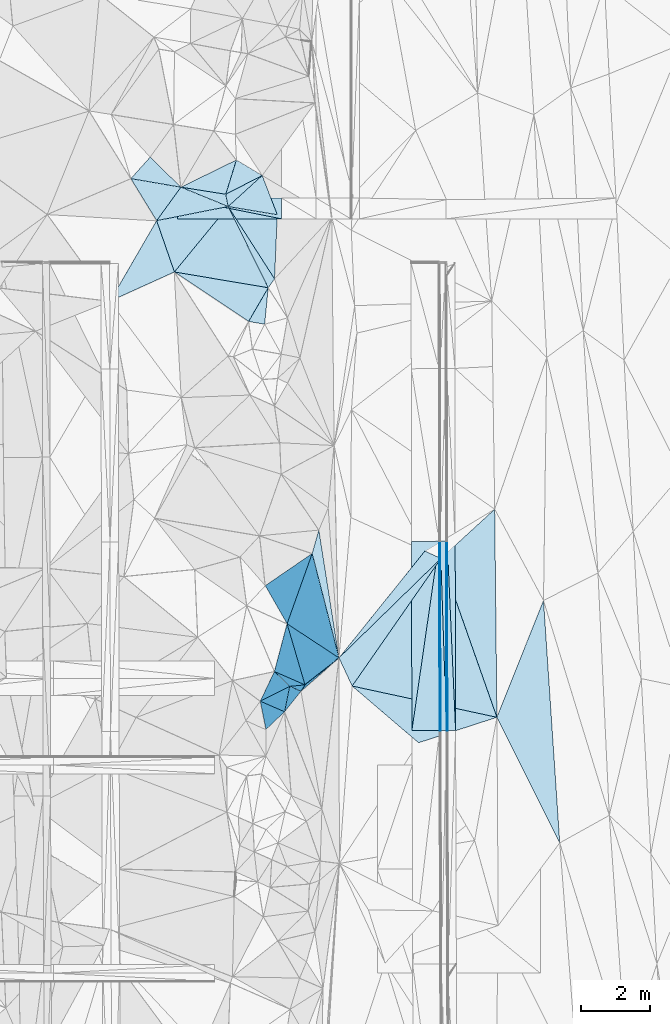
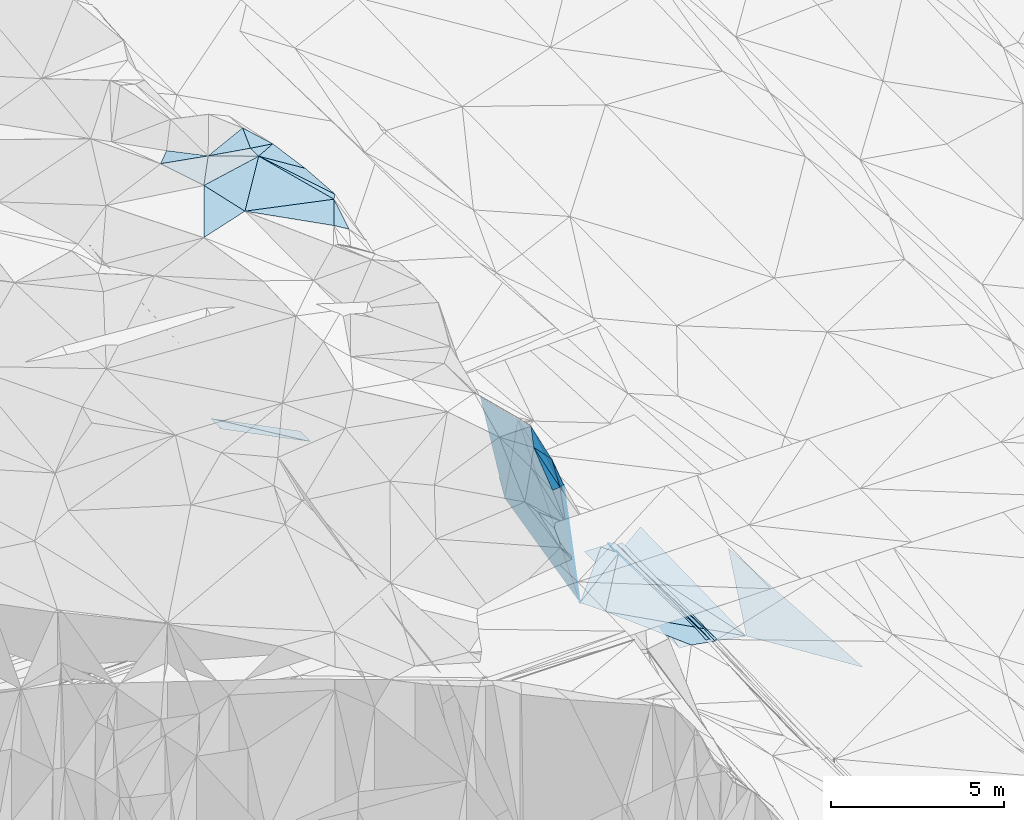
# One storey, part 81 of 275: 45 plates.
"""IFC2X3 building model written with IfcOpenShell, lengths in millimetres."""

from ifc_helpers import new_model, si_unit, frame, origin_with_axes, place, context, subcontext, project, spatial, polyline, outline, extrude, material, type_object, element, save


model = new_model("IFC2X3")

# Units and contexts
model_context = context("Model", 3, precision=1e-05, world=origin_with_axes())
body_context = subcontext(model_context, "Body", "Model", "MODEL_VIEW")
ifc_project = project(units=[si_unit("LENGTHUNIT", "METRE", prefix="MILLI"), si_unit("AREAUNIT", "SQUARE_METRE"), si_unit("VOLUMEUNIT", "CUBIC_METRE"), si_unit("MASSUNIT", "GRAM", prefix="KILO"), si_unit("TIMEUNIT", "SECOND"), si_unit("PLANEANGLEUNIT", "RADIAN"), si_unit("SOLIDANGLEUNIT", "STERADIAN"), si_unit("THERMODYNAMICTEMPERATUREUNIT", "DEGREE_CELSIUS"), si_unit("LUMINOUSINTENSITYUNIT", "LUMEN")], contexts=[model_context])

# Site, building, storey
site_placement = place(None, origin_with_axes())
site = spatial("IfcSite", under=ifc_project, at=site_placement, CompositionType="ELEMENT")
building_placement = place(site_placement, origin_with_axes())
building = spatial("IfcBuilding", under=site, at=building_placement, Name="Undefined", CompositionType="ELEMENT")
storey_placement = place(building_placement, origin_with_axes())
storey = spatial("IfcBuildingStorey", under=building, at=storey_placement, Name="Undefined", CompositionType="ELEMENT", Elevation=0.0)

# Plates
ifc_material = material()
plate_type_1 = type_object("IfcPlateType", PredefinedType="NOTDEFINED")
plate_1_placement = place(storey_placement, frame((-94105.8883228957, 67288.7747028968, 42290.6607411696), z_axis=(-0.970143260568586, 0.00267145694743371, -0.242517870044931), x_axis=(-0.00764659711849112, 0.999105321574431, 0.0415943019434257)))
element("IfcPlate", 1, at=plate_1_placement, inside=storey, type_object=plate_type_1, material=ifc_material, Name="00_PR", context=body_context, shape_type="SweptSolid", body=[
    extrude(outline(polyline([(0.0, 0.0), (5462.623046875, -2.93221091851592e-08), (5457.62060546875, 123.591766357422), (0.0, 0.0)])), frame((-8.85201319254618e-08, 2.18876761149539e-07, -0.5000001331573), z_axis=(0.0, 0.0, 1.0), x_axis=(1.0, 0.0, 0.0)), (0.0, 0.0, 1.0), 1.0),
])
plate_2_placement = place(storey_placement, frame((-94135.8859445538, 67288.478023209, 42410.6607449865), z_axis=(-0.970145116736712, 0.00267113368634195, -0.242510448263043), x_axis=(-0.00215655711744766, 0.999804800462276, 0.0196395069690803)))
element("IfcPlate", 2, at=plate_2_placement, inside=storey, type_object=plate_type_1, material=ifc_material, Name="00_PR", context=body_context, shape_type="SweptSolid", body=[
    extrude(outline(polyline([(0.0, 0.0), (5459.09814453125, -3.5026459954679e-08), (-2.12481045722961, 123.674697875977), (0.0, 0.0)])), frame((-8.85201319254618e-08, 2.18876761149539e-07, -0.5000001331573), z_axis=(0.0, 0.0, 1.0), x_axis=(1.0, 0.0, 0.0)), (0.0, 0.0, 1.0), 1.0),
])
plate_type_2 = type_object("IfcPlateType", PredefinedType="NOTDEFINED")
plate_3_placement = place(storey_placement, frame((-94317.184155341, 72746.2287388931, 42517.496195845), z_axis=(-0.0200433417983263, 0.0195917396136776, -0.999607136923534), x_axis=(0.00215672009275164, -0.999804810953611, -0.0196389549736261)))
element("IfcPlate", 3, at=plate_3_placement, inside=storey, type_object=plate_type_2, material=ifc_material, Name="00_PR", context=body_context, shape_type="SweptSolid", body=[
    extrude(outline(polyline([(0.0, 0.0), (5459.251953125, 9.13860276341438e-09), (5459.25341796875, 30.0063400268555), (0.0, 0.0)])), frame((-8.85201319254618e-08, 2.18876761149539e-07, -0.5000001331573), z_axis=(0.0, 0.0, 1.0), x_axis=(1.0, 0.0, 0.0)), (0.0, 0.0, 1.0), 1.0),
])
plate_4_placement = place(storey_placement, frame((-94317.184155341, 72746.2287388931, 42517.496195845), z_axis=(-0.0200254527998118, 0.0195917848498762, -0.999607494573024), x_axis=(-0.00333853088786553, -0.999803721825275, -0.0195287489573384)))
element("IfcPlate", 4, at=plate_4_placement, inside=storey, type_object=plate_type_2, material=ifc_material, Name="00_PR", context=body_context, shape_type="SweptSolid", body=[
    extrude(outline(polyline([(0.0, 0.0), (5459.3359375, 3.60741978511214e-08), (0.138779759407043, 30.0050926208496), (0.0, 0.0)])), frame((-8.85201319254618e-08, 2.18876761149539e-07, -0.5000001331573), z_axis=(0.0, 0.0, 1.0), x_axis=(1.0, 0.0, 0.0)), (0.0, 0.0, 1.0), 1.0),
])
plate_type_3 = type_object("IfcPlateType", PredefinedType="NOTDEFINED")
plate_5_placement = place(storey_placement, frame((-100194.895762429, 83737.6100265071, 52559.5807201989), z_axis=(-0.517947939485658, 0.169130371912813, -0.838525401689892), x_axis=(0.724175433162463, -0.435056636844825, -0.535066037738547)))
element("IfcPlate", 5, at=plate_5_placement, inside=storey, type_object=plate_type_3, material=ifc_material, Name="00", context=body_context, shape_type="SweptSolid", body=[
    extrude(outline(polyline([(0.0, 0.0), (1027.91052246094, -4.09272615797818e-09), (213.345428466797, 1012.6123046875), (0.0, 0.0)])), frame((-8.85201319254618e-08, 2.18876761149539e-07, -0.5000001331573), z_axis=(0.0, 0.0, 1.0), x_axis=(1.0, 0.0, 0.0)), (0.0, 0.0, 1.0), 1.0),
])
plate_type_4 = type_object("IfcPlateType", PredefinedType="NOTDEFINED")
plate_6_placement = place(storey_placement, frame((-94347.1835203623, 72746.1783840507, 42518.0961953105), z_axis=(-0.0200255458271664, 0.0195891774663647, -0.999607543809327), x_axis=(-0.142854974884149, -0.989605564019306, -0.0165312979793267)))
element("IfcPlate", 6, at=plate_6_placement, inside=storey, type_object=plate_type_4, material=ifc_material, Name="00_PR", context=body_context, shape_type="SweptSolid", body=[
    extrude(outline(polyline([(0.0, 0.0), (5517.6552734375, -2.86236172541976e-08), (115.368087768555, 791.799621582031), (0.0, 0.0)])), frame((-8.85201319254618e-08, 2.18876761149539e-07, -0.5000001331573), z_axis=(0.0, 0.0, 1.0), x_axis=(1.0, 0.0, 0.0)), (0.0, 0.0, 1.0), 1.0),
])
plate_7_placement = place(storey_placement, frame((-95135.4080189212, 67285.876129665, 42426.882196246), z_axis=(-0.0200433417983263, 0.0195917396136776, -0.999607136923534), x_axis=(0.142854974882387, 0.989605564019583, 0.0165312979779408)))
element("IfcPlate", 7, at=plate_7_placement, inside=storey, type_object=plate_type_4, material=ifc_material, Name="00_PR", context=body_context, shape_type="SweptSolid", body=[
    extrude(outline(polyline([(0.0, 0.0), (5517.6552734375, -2.86236172541976e-08), (116.085716247559, 791.694885253906), (0.0, 0.0)])), frame((-8.85201319254618e-08, 2.18876761149539e-07, -0.5000001331573), z_axis=(0.0, 0.0, 1.0), x_axis=(1.0, 0.0, 0.0)), (0.0, 0.0, 1.0), 1.0),
])
plate_type_5 = type_object("IfcPlateType", PredefinedType="NOTDEFINED")
plate_8_placement = place(storey_placement, frame((-94117.1590713783, 72746.7374610893, 42397.4963620172), z_axis=(0.032552225609783, 0.0196996098210919, -0.999275876813178), x_axis=(0.0442497001229491, -0.998853797182877, -0.0182498189683215)))
element("IfcPlate", 8, at=plate_8_placement, inside=storey, type_object=plate_type_5, material=ifc_material, Name="00_PR", context=body_context, shape_type="SweptSolid", body=[
    extrude(outline(polyline([(0.0, 0.0), (5463.8349609375, 2.49419827014208e-08), (5454.17578125, 229.92073059082), (0.0, 0.0)])), frame((-8.85201319254618e-08, 2.18876761149539e-07, -0.5000001331573), z_axis=(0.0, 0.0, 1.0), x_axis=(1.0, 0.0, 0.0)), (0.0, 0.0, 1.0), 1.0),
])
plate_9_placement = place(storey_placement, frame((-93887.1681479151, 72752.6049275204, 42405.014355587), z_axis=(0.0321628345560852, 0.0196825968237391, -0.999288820839897), x_axis=(0.00215608511874656, -0.999805118314939, -0.0196233709696252)))
element("IfcPlate", 9, at=plate_9_placement, inside=storey, type_object=plate_type_5, material=ifc_material, Name="00_PR", context=body_context, shape_type="SweptSolid", body=[
    extrude(outline(polyline([(0.0, 0.0), (5464.50439453125, 1.28202373161912e-08), (5.51798009872437, 230.122604370117), (0.0, 0.0)])), frame((-8.85201319254618e-08, 2.18876761149539e-07, -0.5000001331573), z_axis=(0.0, 0.0, 1.0), x_axis=(1.0, 0.0, 0.0)), (0.0, 0.0, 1.0), 1.0),
])
plate_type_6 = type_object("IfcPlateType", PredefinedType="NOTDEFINED")
plate_10_placement = place(storey_placement, frame((-98896.0430821034, 82040.1903533661, 42078.1398352364), z_axis=(-0.447167143294242, 0.0147002644172727, -0.894329608245265), x_axis=(-0.894427043077974, -0.000120820065553722, 0.447213875023242)))
element("IfcPlate", 10, at=plate_10_placement, inside=storey, type_object=plate_type_6, material=ifc_material, Name="00_PR", context=body_context, shape_type="SweptSolid", body=[
    extrude(outline(polyline([(0.0, 0.0), (3354.10205078125, 2.21771188080311e-08), (3358.47973632813, 600.065795898438), (0.0, 0.0)])), frame((-8.85201319254618e-08, 2.18876761149539e-07, -0.5000001331573), z_axis=(0.0, 0.0, 1.0), x_axis=(1.0, 0.0, 0.0)), (0.0, 0.0, 1.0), 1.0),
])
plate_11_placement = place(storey_placement, frame((-101896.078075438, 82639.7855629946, 43588.0208342081), z_axis=(-0.447165848285199, 0.0147080515013977, -0.894330127720413), x_axis=(0.894427663697687, 0.000120547050021289, -0.447212633856319)))
element("IfcPlate", 11, at=plate_11_placement, inside=storey, type_object=plate_type_6, material=ifc_material, Name="00_PR", context=body_context, shape_type="SweptSolid", body=[
    extrude(outline(polyline([(0.0, 0.0), (3354.10034179688, 1.88592821359634e-08), (3358.47998046875, 600.065002441406), (0.0, 0.0)])), frame((-8.85201319254618e-08, 2.18876761149539e-07, -0.5000001331573), z_axis=(0.0, 0.0, 1.0), x_axis=(1.0, 0.0, 0.0)), (0.0, 0.0, 1.0), 1.0),
])
plate_type_7 = type_object("IfcPlateType", PredefinedType="NOTDEFINED")
plate_12_placement = place(storey_placement, frame((-101794.336478555, 82953.8945160028, 52609.515396825), z_axis=(-0.00599802360612919, 0.246313017119095, -0.969171770797369), x_axis=(0.986678944364957, -0.156105204818657, -0.0457801897700193)))
element("IfcPlate", 12, at=plate_12_placement, inside=storey, type_object=plate_type_7, material=ifc_material, Name="00", context=body_context, shape_type="SweptSolid", body=[
    extrude(outline(polyline([(0.0, 0.0), (1310.61059570313, -2.25554686039686e-09), (1437.19274902344, 347.8173828125), (0.0, 0.0)])), frame((-8.85201319254618e-08, 2.18876761149539e-07, -0.5000001331573), z_axis=(0.0, 0.0, 1.0), x_axis=(1.0, 0.0, 0.0)), (0.0, 0.0, 1.0), 1.0),
])
plate_type_8 = type_object("IfcPlateType", PredefinedType="NOTDEFINED")
plate_13_placement = place(storey_placement, frame((-98733.889735444, 70366.5470563897, 49889.891515002), z_axis=(-0.973499400881543, -0.0723070207710312, -0.216957625426013), x_axis=(0.225599368084809, -0.14820934785337, -0.962880529623802)))
element("IfcPlate", 13, at=plate_13_placement, inside=storey, type_object=plate_type_8, material=ifc_material, Name="00", context=body_context, shape_type="SweptSolid", body=[
    extrude(outline(polyline([(0.0, 0.0), (6632.18310546875, 7.27595761418343e-09), (2043.37243652344, 1479.02978515625), (0.0, 0.0)])), frame((-8.85201319254618e-08, 2.18876761149539e-07, -0.5000001331573), z_axis=(0.0, 0.0, 1.0), x_axis=(1.0, 0.0, 0.0)), (0.0, 0.0, 1.0), 1.0),
])
plate_type_9 = type_object("IfcPlateType", PredefinedType="NOTDEFINED")
plate_14_placement = place(storey_placement, frame((-98217.47107927, 68604.9890517358, 48159.826434278), z_axis=(-0.935447916200831, 0.0666723743340518, -0.347119562364588), x_axis=(-0.334905769035015, 0.14684688182538, 0.930738480543933)))
element("IfcPlate", 14, at=plate_14_placement, inside=storey, type_object=plate_type_9, material=ifc_material, Name="00", context=body_context, shape_type="SweptSolid", body=[
    extrude(outline(polyline([(0.0, 0.0), (2632.318359375, -6.29370333626866e-09), (2041.81225585938, 1481.18286132813), (0.0, 0.0)])), frame((-8.85201319254618e-08, 2.18876761149539e-07, -0.5000001331573), z_axis=(0.0, 0.0, 1.0), x_axis=(1.0, 0.0, 0.0)), (0.0, 0.0, 1.0), 1.0),
])
plate_type_10 = type_object("IfcPlateType", PredefinedType="NOTDEFINED")
plate_15_placement = place(storey_placement, frame((-94135.4008909299, 67288.4865046223, 42410.2820968121), z_axis=(-3.35458323649286e-05, 0.0196394801364128, -0.999807126247182), x_axis=(-0.0332807080927855, 0.999253255527011, 0.019629716949398)))
element("IfcPlate", 15, at=plate_15_placement, inside=storey, type_object=plate_type_10, material=ifc_material, Name="00_PR", context=body_context, shape_type="SweptSolid", body=[
    extrude(outline(polyline([(0.0, 0.0), (5461.82080078125, -3.41970007866621e-08), (5456.453125, 169.915893554688), (0.0, 0.0)])), frame((-8.85201319254618e-08, 2.18876761149539e-07, -0.5000001331573), z_axis=(0.0, 0.0, 1.0), x_axis=(1.0, 0.0, 0.0)), (0.0, 0.0, 1.0), 1.0),
])
plate_16_placement = place(storey_placement, frame((-94135.4008909299, 67288.4865046223, 42410.2820968121), z_axis=(-5.12919770423219e-05, 0.0196388899886033, -0.999807137086523), x_axis=(-0.999996589382712, -0.0026117471056877, -1.19839467036516e-11)))
element("IfcPlate", 16, at=plate_16_placement, inside=storey, type_object=plate_type_10, material=ifc_material, Name="00_PR", context=body_context, shape_type="SweptSolid", body=[
    extrude(outline(polyline([(0.0, 0.0), (169.999771118164, -4.07453626394272e-10), (167.518402099609, 5459.25146484375), (0.0, 0.0)])), frame((-8.85201319254618e-08, 2.18876761149539e-07, -0.5000001331573), z_axis=(0.0, 0.0, 1.0), x_axis=(1.0, 0.0, 0.0)), (0.0, 0.0, 1.0), 1.0),
])
plate_type_11 = type_object("IfcPlateType", PredefinedType="NOTDEFINED")
plate_17_placement = place(storey_placement, frame((-96857.6149185789, 68571.7531211873, 43549.5150766634), z_axis=(-0.195128983654219, -0.14621251668395, -0.969817807478816), x_axis=(-0.42308597775699, 0.904638403090049, -0.0512602680455094)))
element("IfcPlate", 17, at=plate_17_placement, inside=storey, type_object=plate_type_11, material=ifc_material, Name="00", context=body_context, shape_type="SweptSolid", body=[
    extrude(outline(polyline([(0.0, 0.0), (897.381164550781, -1.97906047105789e-09), (2300.1708984375, 3993.98486328125), (0.0, 0.0)])), frame((-8.85201319254618e-08, 2.18876761149539e-07, -0.5000001331573), z_axis=(0.0, 0.0, 1.0), x_axis=(1.0, 0.0, 0.0)), (0.0, 0.0, 1.0), 1.0),
])
plate_type_12 = type_object("IfcPlateType", PredefinedType="NOTDEFINED")
plate_18_placement = place(storey_placement, frame((-92683.8606315439, 67670.5480319391, 41770.5389967916), z_axis=(-0.385822699385651, 0.033101874921256, -0.921978910016638), x_axis=(-0.886973976130164, -0.288239815690379, 0.360825406974929)))
element("IfcPlate", 18, at=plate_18_placement, inside=storey, type_object=plate_type_12, material=ifc_material, Name="00", context=body_context, shape_type="SweptSolid", body=[
    extrude(outline(polyline([(0.0, 0.0), (2546.93823242188, 1.56578607857227e-08), (4084.21533203125, 2171.95263671875), (0.0, 0.0)])), frame((-8.85201319254618e-08, 2.18876761149539e-07, -0.5000001331573), z_axis=(0.0, 0.0, 1.0), x_axis=(1.0, 0.0, 0.0)), (0.0, 0.0, 1.0), 1.0),
])
plate_type_13 = type_object("IfcPlateType", PredefinedType="NOTDEFINED")
plate_19_placement = place(storey_placement, frame((-100501.203023529, 82749.1899029871, 52549.5005655314), z_axis=(-0.0426515486125386, 0.0233347016686052, -0.998817469360138), x_axis=(-0.986678944426331, 0.156105204417745, 0.0457801898143268)))
element("IfcPlate", 19, at=plate_19_placement, inside=storey, type_object=plate_type_13, material=ifc_material, Name="00", context=body_context, shape_type="SweptSolid", body=[
    extrude(outline(polyline([(0.0, 0.0), (1310.61059570313, -2.25554686039686e-09), (-147.717407226563, 1024.24584960938), (0.0, 0.0)])), frame((-8.85201319254618e-08, 2.18876761149539e-07, -0.5000001331573), z_axis=(0.0, 0.0, 1.0), x_axis=(1.0, 0.0, 0.0)), (0.0, 0.0, 1.0), 1.0),
])
plate_type_14 = type_object("IfcPlateType", PredefinedType="NOTDEFINED")
plate_20_placement = place(storey_placement, frame((-94296.9065862147, 72251.5564498804, 42479.5520766519), z_axis=(-0.42815355964446, 0.119135539978553, -0.895818760954355), x_axis=(-0.694631647654902, -0.677474513525666, 0.241899064899799)))
element("IfcPlate", 20, at=plate_20_placement, inside=storey, type_object=plate_type_14, material=ifc_material, Name="00", context=body_context, shape_type="SweptSolid", body=[
    extrude(outline(polyline([(0.0, 0.0), (4233.17041015625, -2.43016984313726e-09), (240.892730712891, 514.267150878906), (0.0, 0.0)])), frame((-8.85201319254618e-08, 2.18876761149539e-07, -0.5000001331573), z_axis=(0.0, 0.0, 1.0), x_axis=(1.0, 0.0, 0.0)), (0.0, 0.0, 1.0), 1.0),
])
plate_type_15 = type_object("IfcPlateType", PredefinedType="NOTDEFINED")
plate_21_placement = place(storey_placement, frame((-100433.08112966, 82396.7788359204, 52459.5719107771), z_axis=(-0.50232133407132, 0.121201003317693, -0.856144610525345), x_axis=(-0.184666852201554, 0.952246851558526, 0.243154451727382)))
element("IfcPlate", 21, at=plate_21_placement, inside=storey, type_object=plate_type_15, material=ifc_material, Name="00", context=body_context, shape_type="SweptSolid", body=[
    extrude(outline(polyline([(0.0, 0.0), (370.135101318359, -1.28056854009628e-09), (560.065734863281, 1285.62292480469), (0.0, 0.0)])), frame((-8.85201319254618e-08, 2.18876761149539e-07, -0.5000001331573), z_axis=(0.0, 0.0, 1.0), x_axis=(1.0, 0.0, 0.0)), (0.0, 0.0, 1.0), 1.0),
])
plate_type_16 = type_object("IfcPlateType", PredefinedType="NOTDEFINED")
plate_22_placement = place(storey_placement, frame((-98010.9909154621, 72391.6054447864, 45629.8349737304), z_axis=(-0.861033162891843, -0.386906846065152, -0.330037853690127), x_axis=(-0.151477092050855, -0.424399155041218, 0.892714986871015)))
element("IfcPlate", 22, at=plate_22_placement, inside=storey, type_object=plate_type_16, material=ifc_material, Name="00", context=body_context, shape_type="SweptSolid", body=[
    extrude(outline(polyline([(0.0, 0.0), (4771.9599609375, 4.26371116191149e-09), (4712.82275390625, 1312.82250976563), (0.0, 0.0)])), frame((-8.85201319254618e-08, 2.18876761149539e-07, -0.5000001331573), z_axis=(0.0, 0.0, 1.0), x_axis=(1.0, 0.0, 0.0)), (0.0, 0.0, 1.0), 1.0),
])
plate_type_17 = type_object("IfcPlateType", PredefinedType="NOTDEFINED")
plate_23_placement = place(storey_placement, frame((-100432.976276777, 82396.7478906865, 52459.5227896047), z_axis=(-0.292620091056618, 0.0593096324890223, -0.954387683179133), x_axis=(0.527383152316001, -0.822542983005744, -0.212814594803197)))
element("IfcPlate", 23, at=plate_23_placement, inside=storey, type_object=plate_type_17, material=ifc_material, Name="00", context=body_context, shape_type="SweptSolid", body=[
    extrude(outline(polyline([(0.0, 0.0), (2537.419921875, 1.21144694276154e-08), (2642.96020507813, 298.263732910156), (0.0, 0.0)])), frame((-8.85201319254618e-08, 2.18876761149539e-07, -0.5000001331573), z_axis=(0.0, 0.0, 1.0), x_axis=(1.0, 0.0, 0.0)), (0.0, 0.0, 1.0), 1.0),
])
plate_type_18 = type_object("IfcPlateType", PredefinedType="NOTDEFINED")
plate_24_placement = place(storey_placement, frame((-97237.6697674867, 69383.7280861783, 43503.9144535275), z_axis=(-0.966203446540597, 0.192826953217151, -0.171080875629226), x_axis=(-0.20638842907441, -0.1810185950604, 0.961579993857275)))
element("IfcPlate", 24, at=plate_24_placement, inside=storey, type_object=plate_type_18, material=ifc_material, Name="00", context=body_context, shape_type="SweptSolid", body=[
    extrude(outline(polyline([(0.0, 0.0), (5310.0107421875, -8.43283487483859e-09), (4820.2939453125, 97.3535690307617), (0.0, 0.0)])), frame((-8.85201319254618e-08, 2.18876761149539e-07, -0.5000001331573), z_axis=(0.0, 0.0, 1.0), x_axis=(1.0, 0.0, 0.0)), (0.0, 0.0, 1.0), 1.0),
])
plate_type_19 = type_object("IfcPlateType", PredefinedType="NOTDEFINED")
plate_25_placement = place(storey_placement, frame((-98333.5828607927, 68422.3497528164, 48609.8494492498), z_axis=(-0.942886834464505, -0.142512065412672, -0.30108923694699), x_axis=(-0.320230161006352, 0.138845523821754, 0.937109686480995)))
element("IfcPlate", 25, at=plate_25_placement, inside=storey, type_object=plate_type_19, material=ifc_material, Name="00", context=body_context, shape_type="SweptSolid", body=[
    extrude(outline(polyline([(0.0, 0.0), (1013.75537109375, 2.06637196242809e-09), (-433.536529541016, 247.681396484375), (0.0, 0.0)])), frame((-8.85201319254618e-08, 2.18876761149539e-07, -0.5000001331573), z_axis=(0.0, 0.0, 1.0), x_axis=(1.0, 0.0, 0.0)), (0.0, 0.0, 1.0), 1.0),
])
plate_type_20 = type_object("IfcPlateType", PredefinedType="NOTDEFINED")
plate_26_placement = place(storey_placement, frame((-97237.3796243666, 69383.8637800372, 43503.6013793758), z_axis=(-0.38591807234532, 0.464217449131272, -0.797226066658214), x_axis=(-0.205470585295766, 0.799212405182308, 0.564837472181977)))
element("IfcPlate", 26, at=plate_26_placement, inside=storey, type_object=plate_type_20, material=ifc_material, Name="00", context=body_context, shape_type="SweptSolid", body=[
    extrude(outline(polyline([(0.0, 0.0), (3763.91455078125, -1.60507624968886e-08), (4433.8046875, 367.895294189453), (0.0, 0.0)])), frame((-8.85201319254618e-08, 2.18876761149539e-07, -0.5000001331573), z_axis=(0.0, 0.0, 1.0), x_axis=(1.0, 0.0, 0.0)), (0.0, 0.0, 1.0), 1.0),
])
plate_type_21 = type_object("IfcPlateType", PredefinedType="NOTDEFINED")
plate_27_placement = place(storey_placement, frame((-97237.6727021407, 69383.5817683008, 43503.8937971743), z_axis=(-0.972074475995734, -0.0998061337641994, -0.21239102801357), x_axis=(-0.225599368106172, 0.148209347850846, 0.962880529619185)))
element("IfcPlate", 27, at=plate_27_placement, inside=storey, type_object=plate_type_21, material=ifc_material, Name="00", context=body_context, shape_type="SweptSolid", body=[
    extrude(outline(polyline([(0.0, 0.0), (6632.18310546875, 7.27595761418343e-09), (2667.39501953125, 2655.57080078125), (0.0, 0.0)])), frame((-8.85201319254618e-08, 2.18876761149539e-07, -0.5000001331573), z_axis=(0.0, 0.0, 1.0), x_axis=(1.0, 0.0, 0.0)), (0.0, 0.0, 1.0), 1.0),
])
plate_type_22 = type_object("IfcPlateType", PredefinedType="NOTDEFINED")
plate_28_placement = place(storey_placement, frame((-99277.0786336165, 80054.2448373237, 51959.5722317127), z_axis=(-0.3843929511639, 0.346969757290959, -0.855484685205387), x_axis=(-0.092249954341878, -0.936480546223348, -0.338369816131908)))
element("IfcPlate", 28, at=plate_28_placement, inside=storey, type_object=plate_type_22, material=ifc_material, Name="00", context=body_context, shape_type="SweptSolid", body=[
    extrude(outline(polyline([(0.0, 0.0), (1123.03161621094, 1.04773789644241e-09), (1009.41058349609, 514.18896484375), (0.0, 0.0)])), frame((-8.85201319254618e-08, 2.18876761149539e-07, -0.5000001331573), z_axis=(0.0, 0.0, 1.0), x_axis=(1.0, 0.0, 0.0)), (0.0, 0.0, 1.0), 1.0),
])
plate_type_23 = type_object("IfcPlateType", PredefinedType="NOTDEFINED")
plate_29_placement = place(storey_placement, frame((-98217.4673536326, 68604.8443976574, 48159.8505990489), z_axis=(-0.927986357460511, -0.222634750768623, -0.29878937082394), x_axis=(-0.300165762238796, -0.0284535761087685, 0.953462589295576)))
element("IfcPlate", 29, at=plate_29_placement, inside=storey, type_object=plate_type_23, material=ifc_material, Name="00", context=body_context, shape_type="SweptSolid", body=[
    extrude(outline(polyline([(0.0, 0.0), (1468.33239746094, -2.69210431724787e-09), (2589.6044921875, 472.280731201172), (0.0, 0.0)])), frame((-8.85201319254618e-08, 2.18876761149539e-07, -0.5000001331573), z_axis=(0.0, 0.0, 1.0), x_axis=(1.0, 0.0, 0.0)), (0.0, 0.0, 1.0), 1.0),
])
plate_type_24 = type_object("IfcPlateType", PredefinedType="NOTDEFINED")
plate_30_placement = place(storey_placement, frame((-98804.799959405, 67831.6020089421, 49059.8256026965), z_axis=(-0.844008765026863, 0.407431293217271, -0.348782089369756), x_axis=(0.163226423668442, 0.814596704705672, 0.556587228832167)))
element("IfcPlate", 30, at=plate_30_placement, inside=storey, type_object=plate_type_24, material=ifc_material, Name="00", context=body_context, shape_type="SweptSolid", body=[
    extrude(outline(polyline([(0.0, 0.0), (898.331787109375, -2.64117261394858e-09), (307.904052734375, 824.072265625), (0.0, 0.0)])), frame((-8.85201319254618e-08, 2.18876761149539e-07, -0.5000001331573), z_axis=(0.0, 0.0, 1.0), x_axis=(1.0, 0.0, 0.0)), (0.0, 0.0, 1.0), 1.0),
])
plate_type_25 = type_object("IfcPlateType", PredefinedType="NOTDEFINED")
plate_31_placement = place(storey_placement, frame((-98804.7570630791, 67831.630559446, 49059.7712380378), z_axis=(-0.758217217447062, 0.464531888254184, -0.457511503638801), x_axis=(-0.423731992147727, 0.18223447786721, 0.887266472885674)))
element("IfcPlate", 31, at=plate_31_placement, inside=storey, type_object=plate_type_25, material=ifc_material, Name="00", context=body_context, shape_type="SweptSolid", body=[
    extrude(outline(polyline([(0.0, 0.0), (1656.77392578125, -8.25821189209819e-10), (514.85595703125, 736.154418945313), (0.0, 0.0)])), frame((-8.85201319254618e-08, 2.18876761149539e-07, -0.5000001331573), z_axis=(0.0, 0.0, 1.0), x_axis=(1.0, 0.0, 0.0)), (0.0, 0.0, 1.0), 1.0),
])
plate_type_26 = type_object("IfcPlateType", PredefinedType="NOTDEFINED")
plate_32_placement = place(storey_placement, frame((-98804.7596836889, 67831.6259214273, 49059.7709381736), z_axis=(-0.763464238252551, 0.455253796579637, -0.458111708657701), x_axis=(-0.642287574025507, -0.609589627266653, 0.464615064953056)))
element("IfcPlate", 32, at=plate_32_placement, inside=storey, type_object=plate_type_26, material=ifc_material, Name="00", context=body_context, shape_type="SweptSolid", body=[
    extrude(outline(polyline([(0.0, 0.0), (839.404541015625, 7.62520357966423e-09), (949.839965820313, 1357.46240234375), (0.0, 0.0)])), frame((-8.85201319254618e-08, 2.18876761149539e-07, -0.5000001331573), z_axis=(0.0, 0.0, 1.0), x_axis=(1.0, 0.0, 0.0)), (0.0, 0.0, 1.0), 1.0),
])
plate_type_27 = type_object("IfcPlateType", PredefinedType="NOTDEFINED")
plate_33_placement = place(storey_placement, frame((-103839.684865221, 79666.0646834405, 52439.507376756), z_axis=(-0.155056929457741, 0.0728835724729334, -0.985213344149743), x_axis=(0.501322802744901, 0.865132035000753, -0.0148999819950758)))
element("IfcPlate", 33, at=plate_33_placement, inside=storey, type_object=plate_type_27, material=ifc_material, Name="00", context=body_context, shape_type="SweptSolid", body=[
    extrude(outline(polyline([(0.0, 0.0), (2684.56689453125, 2.12457962334156e-09), (1664.17895507813, 1202.25134277344), (0.0, 0.0)])), frame((-8.85201319254618e-08, 2.18876761149539e-07, -0.5000001331573), z_axis=(0.0, 0.0, 1.0), x_axis=(1.0, 0.0, 0.0)), (0.0, 0.0, 1.0), 1.0),
])
plate_34_placement = place(storey_placement, frame((-100433.075929462, 82396.6725412321, 52459.5670685805), z_axis=(-0.491923217054247, -0.0913885243317538, -0.865828901194379), x_axis=(0.866759765900336, -0.145174024814904, -0.477128924647665)))
element("IfcPlate", 34, at=plate_34_placement, inside=storey, type_object=plate_type_27, material=ifc_material, Name="00", context=body_context, shape_type="SweptSolid", body=[
    extrude(outline(polyline([(0.0, 0.0), (1634.7783203125, -1.12850102595985e-08), (1720.53918457031, 1865.00537109375), (0.0, 0.0)])), frame((-8.85201319254618e-08, 2.18876761149539e-07, -0.5000001331573), z_axis=(0.0, 0.0, 1.0), x_axis=(1.0, 0.0, 0.0)), (0.0, 0.0, 1.0), 1.0),
])
plate_type_28 = type_object("IfcPlateType", PredefinedType="NOTDEFINED")
plate_35_placement = place(storey_placement, frame((-103237.680370964, 83201.4156770452, 52689.5126840875), z_axis=(-0.0157033152508806, 0.223415171937145, -0.974596874014291), x_axis=(0.984143098447328, -0.168780517853124, -0.054548130781213)))
element("IfcPlate", 35, at=plate_35_placement, inside=storey, type_object=plate_type_28, material=ifc_material, Name="00", context=body_context, shape_type="SweptSolid", body=[
    extrude(outline(polyline([(0.0, 0.0), (1466.5947265625, -8.73114913702011e-11), (952.614929199219, 1095.82153320313), (0.0, 0.0)])), frame((-8.85201319254618e-08, 2.18876761149539e-07, -0.5000001331573), z_axis=(0.0, 0.0, 1.0), x_axis=(1.0, 0.0, 0.0)), (0.0, 0.0, 1.0), 1.0),
])
plate_type_29 = type_object("IfcPlateType", PredefinedType="NOTDEFINED")
plate_36_placement = place(storey_placement, frame((-99098.9662662648, 68991.7089554866, 50609.7548264491), z_axis=(-0.768575425069232, 0.410948282367547, -0.490319615351877), x_axis=(0.362327825230158, -0.352046991007863, -0.863007220819324)))
element("IfcPlate", 36, at=plate_36_placement, inside=storey, type_object=plate_type_29, material=ifc_material, Name="00", context=body_context, shape_type="SweptSolid", body=[
    extrude(outline(polyline([(0.0, 0.0), (1216.67578125, 1.25601218314841e-09), (223.395584106445, 926.981323242188), (0.0, 0.0)])), frame((-8.85201319254618e-08, 2.18876761149539e-07, -0.5000001331573), z_axis=(0.0, 0.0, 1.0), x_axis=(1.0, 0.0, 0.0)), (0.0, 0.0, 1.0), 1.0),
])
plate_type_30 = type_object("IfcPlateType", PredefinedType="NOTDEFINED")
plate_37_placement = place(storey_placement, frame((-99450.4848210463, 83290.3639138557, 52009.5605691082), z_axis=(-0.471129971263353, 0.0754810808777319, -0.878828286189584), x_axis=(0.34594605411102, -0.900693421524454, -0.262816833683819)))
element("IfcPlate", 37, at=plate_37_placement, inside=storey, type_object=plate_type_30, material=ifc_material, Name="00", context=body_context, shape_type="SweptSolid", body=[
    extrude(outline(polyline([(0.0, 0.0), (1255.62731933594, 9.24046617001295e-09), (346.679290771484, 1358.79113769531), (0.0, 0.0)])), frame((-8.85201319254618e-08, 2.18876761149539e-07, -0.5000001331573), z_axis=(0.0, 0.0, 1.0), x_axis=(1.0, 0.0, 0.0)), (0.0, 0.0, 1.0), 1.0),
])
plate_type_31 = type_object("IfcPlateType", PredefinedType="NOTDEFINED")
plate_38_placement = place(storey_placement, frame((-99842.3426197605, 79082.5664671349, 51819.5088280713), z_axis=(-0.060999263349519, 0.177043281711633, -0.982310931564742), x_axis=(-0.822588241410665, 0.548513029992942, 0.149940124786101)))
element("IfcPlate", 38, at=plate_38_placement, inside=storey, type_object=plate_type_31, material=ifc_material, Name="00", context=body_context, shape_type="SweptSolid", body=[
    extrude(outline(polyline([(0.0, 0.0), (2601.03833007813, -1.30967237055302e-09), (88.8106918334961, 1129.34167480469), (0.0, 0.0)])), frame((-8.85201319254618e-08, 2.18876761149539e-07, -0.5000001331573), z_axis=(0.0, 0.0, 1.0), x_axis=(1.0, 0.0, 0.0)), (0.0, 0.0, 1.0), 1.0),
])
plate_type_32 = type_object("IfcPlateType", PredefinedType="NOTDEFINED")
plate_39_placement = place(storey_placement, frame((-101981.893897956, 80509.2455952783, 52209.5041349705), z_axis=(0.00341116938439682, 0.128548591436574, -0.991697344739363), x_axis=(-0.324610615318223, 0.938141851184538, 0.12048989782871)))
element("IfcPlate", 39, at=plate_39_placement, inside=storey, type_object=plate_type_32, material=ifc_material, Name="00", context=body_context, shape_type="SweptSolid", body=[
    extrude(outline(polyline([(0.0, 0.0), (1576.89562988281, 7.10133463144302e-09), (1298.056640625, 2083.25439453125), (0.0, 0.0)])), frame((-8.85201319254618e-08, 2.18876761149539e-07, -0.5000001331573), z_axis=(0.0, 0.0, 1.0), x_axis=(1.0, 0.0, 0.0)), (0.0, 0.0, 1.0), 1.0),
])
plate_type_33 = type_object("IfcPlateType", PredefinedType="NOTDEFINED")
plate_40_placement = place(storey_placement, frame((-102493.780640752, 81988.6449344611, 52399.5127018643), z_axis=(-0.0159040274306265, 0.223553027933854, -0.974562007064246), x_axis=(0.577871354612154, 0.797472449919791, 0.173500400972564)))
element("IfcPlate", 40, at=plate_40_placement, inside=storey, type_object=plate_type_33, material=ifc_material, Name="00", context=body_context, shape_type="SweptSolid", body=[
    extrude(outline(polyline([(0.0, 0.0), (1210.37182617188, 4.77302819490433e-09), (1526.88610839844, 1444.40942382813), (0.0, 0.0)])), frame((-8.85201319254618e-08, 2.18876761149539e-07, -0.5000001331573), z_axis=(0.0, 0.0, 1.0), x_axis=(1.0, 0.0, 0.0)), (0.0, 0.0, 1.0), 1.0),
])
plate_type_34 = type_object("IfcPlateType", PredefinedType="NOTDEFINED")
plate_41_placement = place(storey_placement, frame((-100432.860222935, 82396.8080878444, 52459.5090543315), z_axis=(-0.0605097303959368, 0.179704052115342, -0.98185794602923), x_axis=(0.43460825108493, -0.880781461566974, -0.187988523715795)))
element("IfcPlate", 41, at=plate_41_placement, inside=storey, type_object=plate_type_34, material=ifc_material, Name="00", context=body_context, shape_type="SweptSolid", body=[
    extrude(outline(polyline([(0.0, 0.0), (2659.73681640625, 2.14786268770695e-08), (1036.26794433594, 2225.09521484375), (0.0, 0.0)])), frame((-8.85201319254618e-08, 2.18876761149539e-07, -0.5000001331573), z_axis=(0.0, 0.0, 1.0), x_axis=(1.0, 0.0, 0.0)), (0.0, 0.0, 1.0), 1.0),
])
plate_type_35 = type_object("IfcPlateType", PredefinedType="NOTDEFINED")
plate_42_placement = place(storey_placement, frame((-101794.370368455, 82953.7164504227, 52609.504377452), z_axis=(-0.0737732122800647, -0.109815536266893, -0.99121040205614), x_axis=(-0.984143098449635, 0.168780517841409, 0.054548130775836)))
element("IfcPlate", 42, at=plate_42_placement, inside=storey, type_object=plate_type_35, material=ifc_material, Name="00", context=body_context, shape_type="SweptSolid", body=[
    extrude(outline(polyline([(0.0, 0.0), (1466.5947265625, -8.73114913702011e-11), (1016.16351318359, 708.81005859375), (0.0, 0.0)])), frame((-8.85201319254618e-08, 2.18876761149539e-07, -0.5000001331573), z_axis=(0.0, 0.0, 1.0), x_axis=(1.0, 0.0, 0.0)), (0.0, 0.0, 1.0), 1.0),
])
plate_type_36 = type_object("IfcPlateType", PredefinedType="NOTDEFINED")
plate_43_placement = place(storey_placement, frame((-94296.8527770549, 72251.5137062893, 42479.5266666207), z_axis=(-0.320535101084887, 0.033647030663316, -0.946638857379119), x_axis=(0.719377233952302, 0.658804057786858, -0.220167228975397)))
element("IfcPlate", 43, at=plate_43_placement, inside=storey, type_object=plate_type_36, material=ifc_material, Name="00", context=body_context, shape_type="SweptSolid", body=[
    extrude(outline(polyline([(0.0, 0.0), (2152.90893554688, 6.44649844616652e-09), (-1701.48669433594, 4603.77197265625), (0.0, 0.0)])), frame((-8.85201319254618e-08, 2.18876761149539e-07, -0.5000001331573), z_axis=(0.0, 0.0, 1.0), x_axis=(1.0, 0.0, 0.0)), (0.0, 0.0, 1.0), 1.0),
])
plate_44_placement = place(storey_placement, frame((-90872.2294130701, 64050.832388532, 42226.525995334), z_axis=(0.315979082182371, 0.038690638951812, -0.947976926976963), x_axis=(-0.444681381639304, 0.888664973052499, -0.111951036140629)))
element("IfcPlate", 44, at=plate_44_placement, inside=storey, type_object=plate_type_36, material=ifc_material, Name="00", context=body_context, shape_type="SweptSolid", body=[
    extrude(outline(polyline([(0.0, 0.0), (4073.20922851563, 2.23953975364566e-08), (6404.17333984375, 2838.72778320313), (0.0, 0.0)])), frame((-8.85201319254618e-08, 2.18876761149539e-07, -0.5000001331573), z_axis=(0.0, 0.0, 1.0), x_axis=(1.0, 0.0, 0.0)), (0.0, 0.0, 1.0), 1.0),
])
plate_type_37 = type_object("IfcPlateType", PredefinedType="NOTDEFINED")
plate_45_placement = place(storey_placement, frame((-94296.8881583839, 72251.4992186162, 42479.5398445334), z_axis=(-0.391236889109991, 0.00467202918382956, -0.920278147487401), x_axis=(0.328643222364047, -0.933341655254887, -0.144454099838818)))
element("IfcPlate", 45, at=plate_45_placement, inside=storey, type_object=plate_type_37, material=ifc_material, Name="00", context=body_context, shape_type="SweptSolid", body=[
    extrude(outline(polyline([(0.0, 0.0), (4908.13330078125, 1.97178451344371e-08), (2438.22631835938, 3911.23413085938), (0.0, 0.0)])), frame((-8.85201319254618e-08, 2.18876761149539e-07, -0.5000001331573), z_axis=(0.0, 0.0, 1.0), x_axis=(1.0, 0.0, 0.0)), (0.0, 0.0, 1.0), 1.0),
])

save(model, "model.ifc")
